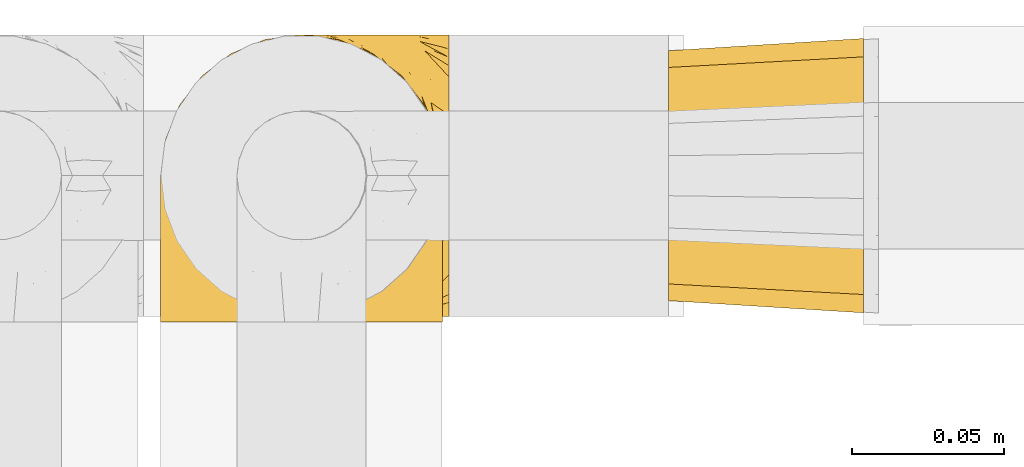
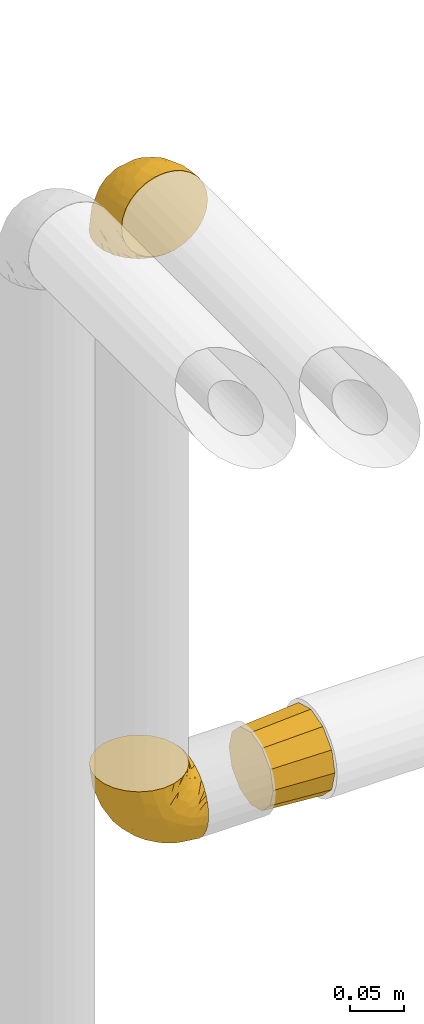
# One storey, part 307 of 827: 3 coverings.
"""IFC2X3 building model written with IfcOpenShell, lengths in millimetres."""

import ifcopenshell
import ifcopenshell.guid

model = None  # the IFC model being written
_history = None  # IfcOwnerHistory: only IFC2X3 demands one
_inside = {}  # id of a spatial element -> (the spatial element, [elements in it])
_under = {}  # id of a project, library or spatial element -> (it, [spatial elements below it])
_declared = {}  # id of a project -> (the project, [libraries it declares])
_typed = {}  # id of a type object -> (the type object, [elements of that type])
_made_of = {}  # id of a material, layer set ... -> (it, [elements and type objects made of it])


def new_model(schema):
    """Start an empty IFC model of exactly this schema.

    Asked for "IFC4X3", IfcOpenShell would pick the latest addendum, in which some entities
    have other attributes; the version numbers below select the first issue.
    IFC2X3 requires an IfcOwnerHistory on every rooted entity: one is made here for all.
    """
    global model, _history
    if schema == "IFC4X3":
        model = ifcopenshell.file(schema_version=(4, 3, 0, 0))
    else:
        model = ifcopenshell.file(schema=schema)
    _inside.clear()
    _under.clear()
    _declared.clear()
    _typed.clear()
    _made_of.clear()
    _history = None
    if model.schema == "IFC2X3":
        org = make("IfcOrganization", Name="unknown")
        user = make(
            "IfcPersonAndOrganization",
            ThePerson=make("IfcPerson", FamilyName="unknown"),
            TheOrganization=org,
        )
        app = make(
            "IfcApplication",
            ApplicationDeveloper=org,
            Version="unknown",
            ApplicationFullName="unknown",
            ApplicationIdentifier="unknown",
        )
        _history = make(
            "IfcOwnerHistory",
            OwningUser=user,
            OwningApplication=app,
            ChangeAction="ADDED",
            CreationDate=0,
        )
    return model


def make(cls, **values):
    """One entity of the class cls with the attributes given. An attribute that is None is left unset."""
    return model.create_entity(
        cls, **{name: value for name, value in values.items() if value is not None}
    )


def entity(cls, *values):
    """Any entity or typed value of the class cls, its attributes in the order of the schema. None: left unset."""
    e = model.create_entity(cls)
    for i, value in enumerate(values):
        if value is not None:
            e[i] = value
    return e


def rooted(cls, **values):
    """An entity with a GlobalId (a new one), such as an element, a storey or a relation."""
    return make(cls, GlobalId=ifcopenshell.guid.new(), OwnerHistory=_history, **values)


def si_unit(unit_type, name, prefix=None):
    """IfcSIUnit, for example si_unit("LENGTHUNIT", "METRE", prefix="MILLI")."""
    return make("IfcSIUnit", UnitType=unit_type, Prefix=prefix, Name=name)


def converted_unit(unit_type, name, factor, base, dimensions=None, offset=None):
    """IfcConversionBasedUnit, such as the inch: factor (a typed value) times the base unit."""
    return make(
        "IfcConversionBasedUnit"
        if offset is None
        else "IfcConversionBasedUnitWithOffset",
        ConversionOffset=offset,
        Dimensions=None
        if dimensions is None
        else entity("IfcDimensionalExponents", *dimensions),
        UnitType=unit_type,
        Name=name,
        ConversionFactor=make(
            "IfcMeasureWithUnit", ValueComponent=factor, UnitComponent=base
        ),
    )


def derived_unit(unit_type, elements):
    """IfcDerivedUnit: a product of units, each with its exponent."""
    return make(
        "IfcDerivedUnit",
        Elements=[
            make("IfcDerivedUnitElement", Unit=unit, Exponent=power)
            for unit, power in elements
        ],
        UnitType=unit_type,
    )


def assignment(units):
    """IfcUnitAssignment: the units of a project."""
    return None if units is None else make("IfcUnitAssignment", Units=units)


def point(xyz):
    """IfcCartesianPoint."""
    return None if xyz is None else make("IfcCartesianPoint", Coordinates=xyz)


def direction(xyz):
    """IfcDirection."""
    return None if xyz is None else make("IfcDirection", DirectionRatios=xyz)


def frame(location, z_axis=None, x_axis=None):
    """IfcAxis2Placement3D, a coordinate frame: its origin and axes. An axis left out is left unset."""
    return make(
        "IfcAxis2Placement3D",
        Location=point(location),
        Axis=direction(z_axis),
        RefDirection=direction(x_axis),
    )


def origin():
    """The frame at (0, 0, 0) with its axes left unset."""
    return frame((0.0, 0.0, 0.0))


def place(relative_to, where):
    """IfcLocalPlacement: puts the frame where relative to a parent placement (None: the world)."""
    return make(
        "IfcLocalPlacement", PlacementRelTo=relative_to, RelativePlacement=where
    )


def context(
    kind, dimensions, precision=None, world=None, true_north=None, identifier=None
):
    """IfcGeometricRepresentationContext, for example the 3D "Model" context."""
    return make(
        "IfcGeometricRepresentationContext",
        ContextIdentifier=identifier,
        ContextType=kind,
        CoordinateSpaceDimension=dimensions,
        Precision=precision,
        WorldCoordinateSystem=world,
        TrueNorth=true_north,
    )


def subcontext(parent, identifier, kind, view, scale=None):
    """IfcGeometricRepresentationSubContext, for example "Body" below "Model"."""
    return make(
        "IfcGeometricRepresentationSubContext",
        ContextIdentifier=identifier,
        ContextType=kind,
        ParentContext=parent,
        TargetScale=scale,
        TargetView=view,
    )


def project(units=None, contexts=None):
    """IfcProject with its units and contexts."""
    return rooted(
        "IfcProject",
        Name="project",
        RepresentationContexts=contexts,
        UnitsInContext=assignment(units),
    )


def spatial(cls, under=None, at=None, **own):
    """A site, building, storey or space (cls), placed at a placement, below another one or the project."""
    s = rooted(cls, ObjectPlacement=at, **own)
    if under is not None:
        _under.setdefault(under.id(), (under, []))[1].append(s)
    return s


def faces_of(points, faces, orient=None, outer=None):
    """IfcFace entities. A face is a list of loops; a loop is a list of indices into points, from 0.

    orient and outer hold one flag for each loop. By default every Orientation is true, the
    first loop of a face is its IfcFaceOuterBound and the others are IfcFaceBound.
    """
    made = []
    for i, loops in enumerate(faces):
        bounds = []
        for j, loop in enumerate(loops):
            is_outer = j == 0 if outer is None else outer[i][j]
            bounds.append(
                make(
                    "IfcFaceOuterBound" if is_outer else "IfcFaceBound",
                    Bound=make("IfcPolyLoop", Polygon=[points[k] for k in loop]),
                    Orientation=True if orient is None else orient[i][j],
                )
            )
        made.append(make("IfcFace", Bounds=bounds))
    return made


def faceted_brep(points, faces, orient=None, outer=None, voids=None):
    """IfcFacetedBrep: a solid bounded by flat faces; with voids (closed shells), ...WithVoids."""
    shared = [point(p) for p in points]
    hull = make("IfcClosedShell", CfsFaces=faces_of(shared, faces, orient, outer))
    if voids is None:
        return make("IfcFacetedBrep", Outer=hull)
    return make(
        "IfcFacetedBrepWithVoids",
        Outer=hull,
        Voids=[
            make(cls, CfsFaces=faces_of(shared, fs, o, b)) for cls, fs, o, b in voids
        ],
    )


def shape(context_of_items, identifier, shape_type, items):
    """IfcShapeRepresentation: the items that make up one representation, for example the "Body"."""
    return make(
        "IfcShapeRepresentation",
        ContextOfItems=context_of_items,
        RepresentationIdentifier=identifier,
        RepresentationType=shape_type,
        Items=items,
    )


def made_of(thing, what):
    """Note that an element or type object is made of a material, layer set ...; save() writes the relation."""
    if what is not None:
        _made_of.setdefault(what.id(), (what, []))[1].append(thing)
    return thing


def element(
    cls,
    number,
    at=None,
    inside=None,
    cuts=None,
    type_object=None,
    material=None,
    context=None,
    identifier="Body",
    shape_type=None,
    held_by="IfcProductDefinitionShape",
    body=None,
    shapes=None,
    **own,
):
    """One element of the class cls, such as IfcWall. Its Tag is "e" and its number.

    at: its placement. inside: the storey or other place that contains it. cuts: it is an
    opening in that element (IfcRelVoidsElement). A single representation is given by context,
    identifier, shape_type and body (its items); several are given by shapes. held_by: the class
    of the entity that holds the representations. save() writes the other relations.
    """
    e = rooted(cls, Tag="e%d" % number, ObjectPlacement=at, **own)
    if body is not None:
        shapes = [shape(context, identifier, shape_type, body)]
    if shapes is not None:
        e.Representation = make(held_by, Representations=shapes)
    if inside is not None:
        _inside.setdefault(inside.id(), (inside, []))[1].append(e)
    if cuts is not None:
        rooted(
            "IfcRelVoidsElement", RelatingBuildingElement=cuts, RelatedOpeningElement=e
        )
    if type_object is not None:
        _typed.setdefault(type_object.id(), (type_object, []))[1].append(e)
    return made_of(e, material)


def aggregate(whole, parts):
    """IfcRelAggregates: a whole, such as a stair, and the parts it consists of."""
    return rooted("IfcRelAggregates", RelatingObject=whole, RelatedObjects=parts)


def save(model, path):
    """Write the relations noted so far, then the file.

    IfcRelAggregates (storeys below a building ...), IfcRelContainedInSpatialStructure (elements
    in a storey), IfcRelDefinesByType, IfcRelAssociatesMaterial and IfcRelDeclares: one each for
    every whole, place, type object, material and project.
    """
    for whole, parts in _under.values():
        aggregate(whole, parts)
    for where, things in _inside.values():
        rooted(
            "IfcRelContainedInSpatialStructure",
            RelatedElements=things,
            RelatingStructure=where,
        )
    for kind, things in _typed.values():
        rooted("IfcRelDefinesByType", RelatedObjects=things, RelatingType=kind)
    for what, things in _made_of.values():
        rooted("IfcRelAssociatesMaterial", RelatedObjects=things, RelatingMaterial=what)
    for by, libraries in _declared.values():
        rooted("IfcRelDeclares", RelatingContext=by, RelatedDefinitions=libraries)
    model.write(path)


model = new_model("IFC2X3")

# Units and contexts
model_context = context("Model", 3, precision=0.01, world=origin(), true_north=direction((6.12303176911189e-17, 1.0)))
body_context = subcontext(model_context, "Body", "Model", "MODEL_VIEW")
ifc_project = project(units=[si_unit("LENGTHUNIT", "METRE", prefix="MILLI"), si_unit("AREAUNIT", "SQUARE_METRE"), si_unit("VOLUMEUNIT", "CUBIC_METRE"), converted_unit("PLANEANGLEUNIT", "DEGREE", entity("IfcRatioMeasure", 0.0174532925199433), si_unit("PLANEANGLEUNIT", "RADIAN"), dimensions=[0, 0, 0, 0, 0, 0, 0]), si_unit("MASSUNIT", "GRAM", prefix="KILO"), derived_unit("MASSDENSITYUNIT", [(si_unit("MASSUNIT", "GRAM", prefix="KILO"), 1), (si_unit("LENGTHUNIT", "METRE"), -3)]), derived_unit("MOMENTOFINERTIAUNIT", [(si_unit("LENGTHUNIT", "METRE"), 4)]), si_unit("TIMEUNIT", "SECOND"), si_unit("FREQUENCYUNIT", "HERTZ"), si_unit("THERMODYNAMICTEMPERATUREUNIT", "DEGREE_CELSIUS"), derived_unit("THERMALTRANSMITTANCEUNIT", [(si_unit("MASSUNIT", "GRAM", prefix="KILO"), 1), (si_unit("THERMODYNAMICTEMPERATUREUNIT", "KELVIN"), -1), (si_unit("TIMEUNIT", "SECOND"), -3)]), derived_unit("VOLUMETRICFLOWRATEUNIT", [(si_unit("LENGTHUNIT", "METRE"), 3), (si_unit("TIMEUNIT", "SECOND"), -1)]), derived_unit("MASSFLOWRATEUNIT", [(si_unit("MASSUNIT", "GRAM", prefix="KILO"), 1), (si_unit("TIMEUNIT", "SECOND"), -1)]), derived_unit("ROTATIONALFREQUENCYUNIT", [(si_unit("TIMEUNIT", "SECOND"), -1)]), si_unit("ELECTRICCURRENTUNIT", "AMPERE"), si_unit("ELECTRICVOLTAGEUNIT", "VOLT"), si_unit("POWERUNIT", "WATT"), si_unit("FORCEUNIT", "NEWTON", prefix="KILO"), si_unit("ILLUMINANCEUNIT", "LUX"), si_unit("LUMINOUSFLUXUNIT", "LUMEN"), si_unit("LUMINOUSINTENSITYUNIT", "CANDELA"), derived_unit("USERDEFINED", [(si_unit("MASSUNIT", "GRAM", prefix="KILO"), -1), (si_unit("LENGTHUNIT", "METRE"), -2), (si_unit("TIMEUNIT", "SECOND"), 3), (si_unit("LUMINOUSFLUXUNIT", "LUMEN"), 1)]), derived_unit("LINEARVELOCITYUNIT", [(si_unit("LENGTHUNIT", "METRE"), 1), (si_unit("TIMEUNIT", "SECOND"), -1)]), si_unit("PRESSUREUNIT", "PASCAL"), derived_unit("USERDEFINED", [(si_unit("LENGTHUNIT", "METRE"), -2), (si_unit("MASSUNIT", "GRAM", prefix="KILO"), 1), (si_unit("TIMEUNIT", "SECOND"), -2)]), derived_unit("LINEARFORCEUNIT", [(si_unit("MASSUNIT", "GRAM", prefix="KILO"), 1), (si_unit("LENGTHUNIT", "METRE"), 1), (si_unit("TIMEUNIT", "SECOND"), -2), (si_unit("LENGTHUNIT", "METRE"), -1)]), derived_unit("PLANARFORCEUNIT", [(si_unit("MASSUNIT", "GRAM", prefix="KILO"), 1), (si_unit("LENGTHUNIT", "METRE"), 1), (si_unit("TIMEUNIT", "SECOND"), -2), (si_unit("LENGTHUNIT", "METRE"), -2)])], contexts=[model_context])

# Site, building, storey
site_placement = place(None, origin())
site = spatial("IfcSite", under=ifc_project, at=site_placement, CompositionType="ELEMENT")
building_placement = place(site_placement, origin())
building = spatial("IfcBuilding", under=site, at=building_placement, CompositionType="ELEMENT")
storey_placement = place(building_placement, frame((0.0, 0.0, 28200.0)))
storey = spatial("IfcBuildingStorey", under=building, at=storey_placement, Name="08", CompositionType="ELEMENT", Elevation=28200.0)

# Coverings
covering_1_placement = place(storey_placement, frame((28292.43, 19468.41, 2252.2)))
element("IfcCovering", 1, at=covering_1_placement, inside=storey, Name=":ADSK_", ObjectType=":ADSK_", PredefinedType="INSULATION", context=body_context, shape_type="Brep", body=[
    faceted_brep([(95.8, 11.68, 18.98), (95.8, 19.0, 11.67), (95.8, 27.76, 6.17), (95.8, 37.52, 2.75), (95.8, 47.8, 1.6), (95.8, 58.08, 2.75), (95.8, 67.85, 6.17), (95.8, 76.61, 11.68), (95.8, 83.92, 19.0), (95.8, 89.42, 27.76), (95.8, 92.84, 37.52), (95.8, 94.0, 47.8), (95.8, 93.53, 51.94), (95.8, 93.18, 55.01), (95.8, 92.84, 58.08), (95.8, 91.13, 62.96), (95.8, 89.42, 67.85), (95.8, 86.66, 72.23), (95.8, 83.91, 76.61), (95.8, 80.25, 80.26), (95.8, 76.59, 83.92), (95.8, 67.83, 89.42), (95.8, 62.95, 91.13), (95.8, 58.07, 92.84), (95.8, 47.8, 94.0), (95.8, 37.51, 92.84), (95.8, 32.63, 91.13), (95.8, 27.74, 89.42), (95.8, 18.98, 83.91), (95.8, 15.33, 80.25), (95.8, 11.67, 76.59), (95.8, 8.92, 72.21), (95.8, 6.17, 67.83), (95.8, 4.46, 62.95), (95.8, 2.75, 58.07), (95.8, 2.41, 55.0), (95.8, 2.06, 51.94), (95.8, 1.6, 47.8), (95.8, 2.75, 37.51), (95.8, 6.17, 27.74), (94.0, 47.8, 95.8), (92.42, 59.75, 95.8), (87.81, 70.9, 95.8), (84.13, 75.68, 95.8), (80.46, 80.46, 95.8), (75.68, 84.13, 95.8), (70.9, 87.81, 95.8), (65.32, 90.11, 95.8), (59.75, 92.42, 95.8), (56.14, 92.9, 95.8), (54.06, 93.17, 95.8), (51.97, 93.45, 95.8), (47.8, 94.0, 95.8), (35.84, 92.42, 95.8), (24.7, 87.81, 95.8), (15.13, 80.46, 95.8), (7.78, 70.9, 95.8), (3.17, 59.75, 95.8), (1.6, 47.8, 95.8), (3.17, 35.84, 95.8), (7.78, 24.7, 95.8), (15.13, 15.13, 95.8), (24.7, 7.78, 95.8), (35.84, 3.17, 95.8), (47.8, 1.6, 95.8), (51.97, 2.14, 95.8), (56.14, 2.69, 95.8), (59.75, 3.17, 95.8), (65.32, 5.48, 95.8), (70.9, 7.78, 95.8), (75.68, 11.46, 95.8), (80.46, 15.13, 95.8), (84.13, 19.91, 95.8), (87.81, 24.7, 95.8), (92.42, 35.84, 95.8), (15.84, 23.61, 60.58), (6.99, 31.99, 74.11), (14.39, 35.87, 51.59), (6.21, 47.8, 66.69), (4.26, 40.43, 76.19), (3.39, 47.8, 84.43), (31.2, 31.83, 31.2), (26.47, 23.37, 42.88), (11.44, 21.41, 79.41), (47.66, 3.07, 60.7), (61.85, 1.6, 61.85), (59.25, 1.6, 65.75), (56.65, 1.6, 69.64), (54.05, 1.6, 73.53), (51.45, 1.6, 77.43), (19.8, 13.45, 74.59), (26.22, 15.25, 54.72), (31.58, 8.07, 64.18), (38.36, 16.0, 37.94), (51.54, 17.34, 25.89), (51.6, 10.58, 34.73), (55.97, 5.34, 42.89), (62.88, 2.39, 49.83), (41.35, 8.36, 48.58), (82.24, 10.04, 22.41), (40.88, 2.59, 78.69), (29.0, 6.28, 81.64), (74.06, 34.28, 6.22), (54.53, 38.73, 12.11), (57.98, 27.25, 14.81), (43.81, 29.88, 21.61), (38.22, 38.6, 22.41), (38.33, 23.44, 30.12), (74.76, 25.25, 10.01), (76.85, 17.23, 15.36), (84.43, 47.8, 3.39), (40.43, 47.8, 19.59), (30.01, 47.8, 30.01), (78.67, 2.53, 41.19), (92.06, 1.6, 48.54), (88.32, 1.6, 49.28), (85.6, 1.6, 49.82), (82.88, 1.6, 50.37), (80.15, 1.6, 50.91), (77.43, 1.6, 51.45), (76.36, 5.71, 31.61), (50.91, 1.6, 80.15), (50.37, 1.6, 82.88), (49.82, 1.6, 85.6), (49.28, 1.6, 88.32), (48.91, 1.6, 90.19), (48.54, 1.6, 92.06), (66.69, 47.8, 6.21), (73.53, 1.6, 54.05), (69.64, 1.6, 56.65), (65.75, 1.6, 59.25), (66.13, 11.89, 24.66), (19.59, 47.8, 40.43), (24.64, 39.69, 35.17), (53.56, 47.8, 12.9), (12.9, 47.8, 53.56), (82.81, 13.84, 85.34), (81.22, 9.16, 78.44), (86.57, 15.79, 84.37), (92.75, 25.75, 89.05), (89.68, 16.09, 82.76), (72.26, 7.51, 86.31), (64.73, 3.99, 83.73), (62.45, 2.66, 77.31), (60.63, 3.16, 87.78), (56.91, 2.35, 87.91), (58.14, 2.23, 81.29), (93.7, 38.35, 93.97), (83.4, 6.18, 70.76), (75.54, 2.7, 63.67), (79.46, 2.93, 62.62), (82.28, 16.01, 90.64), (76.25, 9.08, 84.08), (90.18, 11.68, 77.45), (87.92, 6.83, 70.34), (65.12, 4.65, 88.72), (71.71, 3.65, 71.28), (75.21, 3.61, 68.09), (78.6, 12.8, 91.07), (87.27, 2.43, 57.47), (86.94, 21.65, 91.35), (86.1, 3.7, 62.99), (94.52, 47.8, 94.52), (66.23, 3.37, 76.47), (84.69, 9.3, 76.28), (91.08, 7.03, 69.96), (71.77, 7.87, 89.86), (76.21, 7.26, 78.94), (68.59, 3.41, 73.51), (89.94, 23.81, 89.62), (76.25, 86.5, 84.09), (72.26, 88.08, 86.3), (78.6, 82.79, 91.06), (49.28, 94.0, 88.32), (48.54, 94.0, 92.06), (50.37, 94.0, 82.88), (49.82, 94.0, 85.6), (93.7, 57.24, 93.97), (89.95, 71.76, 89.63), (82.88, 94.0, 50.37), (85.6, 94.0, 49.82), (92.06, 94.0, 48.54), (88.32, 94.0, 49.28), (89.68, 79.49, 82.77), (87.92, 88.75, 70.36), (62.45, 92.93, 77.31), (66.24, 92.22, 76.47), (56.65, 94.0, 69.64), (59.25, 94.0, 65.75), (60.63, 92.43, 87.78), (56.91, 93.24, 87.91), (92.76, 69.82, 89.06), (82.28, 79.57, 90.65), (82.81, 81.74, 85.35), (54.05, 94.0, 73.53), (51.45, 94.0, 77.43), (58.14, 93.36, 81.29), (90.18, 83.9, 77.46), (84.7, 86.28, 76.29), (87.25, 93.16, 57.47), (75.58, 92.88, 63.71), (75.2, 91.98, 68.11), (83.39, 89.41, 70.77), (71.7, 91.93, 71.31), (81.22, 86.42, 78.46), (90.73, 88.82, 69.52), (79.47, 92.66, 62.64), (86.94, 73.93, 91.35), (65.75, 94.0, 59.25), (86.75, 79.5, 84.6), (86.08, 91.89, 62.98), (77.43, 94.0, 51.45), (73.53, 94.0, 54.05), (69.64, 94.0, 56.65), (64.73, 91.6, 83.73), (50.91, 94.0, 80.15), (65.12, 90.94, 88.72), (61.85, 94.0, 61.85), (68.62, 92.16, 73.56), (76.22, 88.32, 78.96), (74.03, 86.13, 91.36), (80.15, 94.0, 50.91), (49.81, 93.2, 62.87), (4.26, 55.16, 76.19), (19.95, 82.02, 73.57), (30.61, 84.29, 56.07), (25.71, 76.94, 49.77), (22.43, 68.33, 44.73), (15.85, 71.98, 60.58), (60.69, 92.52, 47.64), (40.49, 92.9, 78.32), (14.39, 59.72, 51.59), (6.99, 63.6, 74.11), (29.56, 88.89, 76.04), (11.45, 74.18, 79.41), (57.98, 68.35, 14.82), (74.06, 61.33, 6.22), (54.52, 56.86, 12.12), (43.47, 68.62, 23.51), (31.2, 63.76, 31.2), (33.27, 72.19, 34.96), (64.26, 88.69, 33.86), (74.29, 92.19, 38.94), (80.41, 89.75, 30.23), (41.67, 59.86, 20.67), (24.64, 55.9, 35.17), (73.62, 77.99, 15.85), (78.98, 85.21, 22.59), (53.69, 74.99, 21.56), (42.86, 90.23, 55.94), (79.66, 70.75, 9.19), (58.41, 81.72, 25.79), (47.11, 86.53, 41.16), (38.37, 79.6, 37.95)], [[[0, 1, 2, 3, 4, 5, 6, 7, 8, 9, 10, 11, 12, 13, 14, 15, 16, 17, 18, 19, 20, 21, 22, 23, 24, 25, 26, 27, 28, 29, 30, 31, 32, 33, 34, 35, 36, 37, 38, 39]], [[40, 41, 42, 43, 44, 45, 46, 47, 48, 49, 50, 51, 52, 53, 54, 55, 56, 57, 58, 59, 60, 61, 62, 63, 64, 65, 66, 67, 68, 69, 70, 71, 72, 73, 74]], [[75, 76, 77]], [[78, 79, 80]], [[77, 81, 82]], [[76, 75, 83]], [[84, 85, 86, 87, 88, 89]], [[90, 91, 92]], [[76, 60, 59]], [[93, 94, 95]], [[90, 62, 61]], [[83, 61, 60]], [[96, 97, 84]], [[98, 93, 95]], [[0, 39, 99]], [[100, 84, 89]], [[62, 101, 63]], [[2, 102, 3]], [[92, 84, 100]], [[103, 102, 104]], [[103, 105, 106]], [[93, 107, 94]], [[1, 108, 2]], [[92, 101, 90]], [[108, 1, 109]], [[102, 110, 3]], [[93, 82, 107]], [[102, 108, 104]], [[111, 106, 112]], [[109, 0, 99]], [[113, 37, 114, 115, 116, 117, 118, 119]], [[120, 38, 113]], [[100, 89, 121, 122, 123, 124, 125, 126, 64]], [[127, 102, 103]], [[97, 119, 128, 129, 130, 85]], [[99, 120, 131]], [[132, 133, 77]], [[59, 80, 79]], [[1, 0, 109]], [[98, 84, 92]], [[94, 109, 131]], [[120, 39, 38]], [[93, 91, 82]], [[104, 94, 105]], [[97, 113, 119]], [[95, 120, 96]], [[83, 90, 61]], [[91, 93, 98]], [[64, 63, 100]], [[100, 63, 101]], [[77, 76, 79]], [[133, 106, 81]], [[84, 97, 85]], [[113, 96, 120]], [[113, 97, 96]], [[37, 113, 38]], [[110, 102, 127]], [[110, 4, 3]], [[103, 111, 134, 127]], [[90, 75, 91]], [[82, 81, 107]], [[91, 75, 82]], [[77, 82, 75]], [[76, 83, 60]], [[90, 83, 75]], [[105, 107, 81]], [[94, 131, 95]], [[105, 94, 107]], [[109, 94, 104]], [[120, 95, 131]], [[98, 95, 96]], [[84, 98, 96]], [[98, 92, 91]], [[106, 105, 81]], [[103, 104, 105]], [[112, 106, 133]], [[103, 106, 111]], [[112, 133, 132]], [[81, 77, 133]], [[77, 78, 135, 132]], [[120, 99, 39]], [[109, 99, 131]], [[59, 58, 80]], [[59, 79, 76]], [[90, 101, 62]], [[100, 101, 92]], [[2, 108, 102]], [[109, 104, 108]], [[78, 77, 79]], [[136, 137, 138]], [[27, 139, 140]], [[141, 142, 143]], [[144, 145, 121]], [[146, 89, 88]], [[147, 139, 25]], [[148, 149, 150]], [[136, 151, 152]], [[147, 40, 74]], [[24, 147, 25]], [[153, 148, 154]], [[33, 116, 34]], [[73, 72, 151]], [[114, 37, 36, 35, 34, 116, 115]], [[146, 155, 144]], [[156, 85, 130]], [[157, 149, 148]], [[151, 158, 152]], [[117, 33, 159]], [[29, 153, 154]], [[160, 74, 73]], [[161, 128, 119]], [[66, 65, 64, 126, 125, 124, 123, 122, 67]], [[162, 147, 24]], [[27, 140, 28]], [[149, 129, 150]], [[139, 27, 26, 25]], [[68, 144, 69]], [[129, 128, 150]], [[163, 87, 86]], [[130, 129, 149]], [[122, 145, 67]], [[153, 164, 148]], [[161, 119, 159]], [[165, 30, 154]], [[150, 154, 148]], [[128, 161, 150]], [[30, 165, 31]], [[145, 144, 68]], [[89, 146, 144]], [[87, 163, 143]], [[166, 155, 142]], [[88, 87, 143]], [[161, 154, 150]], [[154, 30, 29]], [[29, 28, 153]], [[28, 140, 153]], [[164, 153, 140]], [[140, 137, 164]], [[157, 148, 164]], [[156, 130, 157]], [[164, 137, 157]], [[157, 137, 156]], [[167, 137, 136]], [[168, 85, 156]], [[152, 168, 167]], [[167, 168, 156]], [[163, 152, 141]], [[71, 158, 72]], [[152, 167, 136]], [[88, 142, 146]], [[144, 155, 69]], [[146, 142, 155]], [[70, 166, 71]], [[142, 141, 166]], [[70, 69, 155]], [[141, 158, 71]], [[160, 73, 151]], [[138, 137, 140]], [[160, 136, 169]], [[136, 160, 151]], [[74, 160, 169]], [[152, 158, 141]], [[151, 72, 158]], [[168, 152, 163]], [[137, 167, 156]], [[163, 86, 168]], [[85, 168, 86]], [[116, 33, 117]], [[130, 149, 157]], [[67, 145, 68]], [[121, 89, 144]], [[145, 122, 121]], [[40, 147, 162]], [[169, 147, 74]], [[159, 33, 32]], [[161, 159, 32]], [[159, 119, 118, 117]], [[139, 147, 169]], [[139, 169, 138]], [[161, 32, 31]], [[141, 143, 163]], [[88, 143, 142]], [[71, 166, 141]], [[155, 166, 70]], [[139, 138, 140]], [[169, 136, 138]], [[154, 161, 165]], [[161, 31, 165]], [[170, 171, 172]], [[173, 174, 52, 51, 50, 49, 48, 175, 176]], [[177, 178, 41]], [[179, 15, 180]], [[12, 11, 181, 182, 180, 14, 13]], [[183, 21, 20]], [[19, 18, 184]], [[185, 186, 187]], [[186, 188, 187]], [[43, 172, 44]], [[189, 190, 47]], [[23, 22, 21, 191]], [[170, 192, 193]], [[40, 162, 177]], [[194, 195, 196]], [[24, 23, 177]], [[197, 198, 183]], [[199, 15, 179]], [[178, 177, 191]], [[47, 46, 189]], [[200, 201, 202]], [[201, 203, 204]], [[205, 206, 184]], [[207, 41, 178]], [[16, 15, 199]], [[14, 180, 15]], [[202, 201, 198]], [[208, 201, 200]], [[162, 24, 177]], [[48, 47, 190]], [[196, 195, 189]], [[197, 184, 202]], [[204, 193, 209]], [[210, 211, 212]], [[206, 212, 213]], [[205, 17, 210]], [[184, 206, 202]], [[210, 212, 206]], [[185, 194, 214]], [[189, 215, 190]], [[216, 45, 214]], [[186, 171, 170]], [[189, 216, 196]], [[197, 20, 19]], [[194, 185, 187]], [[197, 183, 20]], [[184, 197, 19]], [[197, 202, 198]], [[206, 200, 202]], [[204, 183, 198]], [[201, 208, 203]], [[203, 208, 217]], [[204, 198, 201]], [[217, 188, 218]], [[193, 219, 170]], [[171, 186, 185]], [[170, 218, 186]], [[170, 219, 218]], [[42, 207, 192]], [[171, 220, 172]], [[216, 189, 46]], [[214, 194, 196]], [[44, 220, 45]], [[214, 196, 216]], [[216, 46, 45]], [[214, 45, 220]], [[192, 43, 42]], [[204, 203, 219]], [[207, 193, 192]], [[209, 193, 178]], [[41, 207, 42]], [[193, 207, 178]], [[43, 192, 172]], [[170, 172, 192]], [[204, 219, 193]], [[219, 203, 218]], [[217, 218, 203]], [[188, 186, 218]], [[206, 213, 200]], [[208, 200, 213]], [[199, 210, 16]], [[215, 189, 195]], [[215, 175, 190]], [[175, 48, 190]], [[199, 179, 221, 211]], [[210, 199, 211]], [[23, 191, 177]], [[40, 177, 41]], [[191, 183, 209]], [[21, 183, 191]], [[205, 18, 17]], [[17, 16, 210]], [[171, 185, 214]], [[172, 220, 44]], [[214, 220, 171]], [[191, 209, 178]], [[204, 209, 183]], [[206, 205, 210]], [[18, 205, 184]], [[222, 195, 194, 187, 188, 217]], [[57, 223, 80]], [[224, 225, 226]], [[226, 227, 228]], [[229, 217, 208, 213, 212, 211]], [[230, 52, 174, 173, 176, 175, 215, 195]], [[231, 232, 228]], [[231, 78, 223]], [[223, 57, 232]], [[224, 233, 225]], [[233, 54, 53]], [[234, 232, 56]], [[56, 55, 234]], [[234, 224, 228]], [[235, 236, 237]], [[224, 55, 54]], [[238, 239, 240]], [[52, 230, 53]], [[241, 242, 243]], [[239, 244, 245]], [[11, 10, 242]], [[236, 6, 5]], [[7, 246, 8]], [[8, 247, 9]], [[238, 248, 235]], [[222, 229, 249]], [[242, 211, 221, 179, 180, 182, 181, 11]], [[233, 53, 230]], [[111, 112, 244]], [[250, 6, 236]], [[247, 251, 241]], [[6, 250, 7]], [[127, 236, 110]], [[249, 229, 252]], [[247, 8, 246]], [[235, 246, 250]], [[236, 5, 110]], [[235, 244, 238]], [[237, 236, 127]], [[243, 9, 247]], [[252, 229, 241]], [[56, 232, 57]], [[222, 230, 195]], [[225, 249, 252]], [[249, 233, 230]], [[54, 233, 224]], [[231, 228, 227]], [[245, 132, 231]], [[249, 225, 233]], [[226, 225, 253]], [[235, 250, 236]], [[246, 7, 250]], [[251, 247, 246]], [[243, 247, 241]], [[248, 246, 235]], [[252, 251, 253]], [[229, 222, 217]], [[230, 222, 249]], [[5, 4, 110]], [[237, 127, 134, 111]], [[238, 244, 239]], [[224, 234, 55]], [[232, 234, 228]], [[242, 241, 229]], [[10, 9, 243]], [[211, 242, 229]], [[10, 243, 242]], [[80, 223, 78]], [[80, 58, 57]], [[231, 223, 232]], [[227, 240, 239]], [[224, 226, 228]], [[240, 226, 253]], [[227, 239, 245]], [[226, 240, 227]], [[251, 248, 253]], [[240, 253, 248]], [[244, 235, 237]], [[237, 111, 244]], [[132, 245, 112]], [[112, 245, 244]], [[135, 78, 231, 132]], [[227, 245, 231]], [[248, 238, 240]], [[246, 248, 251]], [[251, 252, 241]], [[225, 252, 253]]]),
])
covering_2_placement = place(storey_placement, frame((28292.09, 19466.61, 2950.29)))
element("IfcCovering", 2, at=covering_2_placement, inside=storey, Name=":ADSK_", ObjectType=":ADSK_", PredefinedType="INSULATION", context=body_context, shape_type="Brep", body=[
    faceted_brep([(92.83, 1.6, 59.93), (89.41, 1.6, 69.69), (83.9, 1.6, 78.45), (76.57, 1.6, 85.76), (67.81, 1.6, 91.26), (58.05, 1.6, 94.67), (47.77, 1.6, 95.82), (37.49, 1.6, 94.65), (27.72, 1.6, 91.23), (18.96, 1.6, 85.72), (11.65, 1.6, 78.4), (6.16, 1.6, 69.64), (2.75, 1.6, 59.87), (1.6, 1.6, 49.6), (2.06, 1.6, 45.45), (2.41, 1.6, 42.38), (2.76, 1.6, 39.31), (4.47, 1.6, 34.43), (6.18, 1.6, 29.54), (8.94, 1.6, 25.17), (11.7, 1.6, 20.79), (15.36, 1.6, 17.13), (19.02, 1.6, 13.48), (27.78, 1.6, 7.98), (32.66, 1.6, 6.28), (37.54, 1.6, 4.57), (47.82, 1.6, 3.42), (58.1, 1.6, 4.58), (62.99, 1.6, 6.3), (67.87, 1.6, 8.01), (76.63, 1.6, 13.52), (80.28, 1.6, 17.18), (83.94, 1.6, 20.84), (86.69, 1.6, 25.22), (89.43, 1.6, 29.6), (91.14, 1.6, 34.49), (92.84, 1.6, 39.37), (93.19, 1.6, 42.43), (93.53, 1.6, 45.5), (94.0, 1.6, 49.64), (47.82, 3.4, 1.62), (35.86, 4.97, 1.61), (24.72, 9.58, 1.61), (19.94, 13.26, 1.6), (15.15, 16.93, 1.6), (11.48, 21.71, 1.6), (7.81, 26.5, 1.6), (5.5, 32.07, 1.6), (3.19, 37.64, 1.6), (2.72, 41.25, 1.6), (2.44, 43.34, 1.6), (2.17, 45.42, 1.6), (1.62, 49.6, 1.6), (3.19, 61.55, 1.6), (7.81, 72.7, 1.6), (15.15, 82.26, 1.6), (24.72, 89.61, 1.61), (35.86, 94.22, 1.61), (47.82, 95.8, 1.62), (59.78, 94.22, 1.63), (70.92, 89.61, 1.63), (80.49, 82.26, 1.64), (87.83, 72.7, 1.64), (92.45, 61.55, 1.64), (94.02, 49.6, 1.64), (93.47, 45.42, 1.64), (92.92, 41.25, 1.64), (92.45, 37.64, 1.64), (90.14, 32.07, 1.64), (87.83, 26.5, 1.64), (84.16, 21.71, 1.64), (80.49, 16.93, 1.64), (75.7, 13.26, 1.63), (70.92, 9.58, 1.63), (59.78, 4.97, 1.63), (71.99, 81.55, 36.84), (63.62, 90.4, 23.31), (59.72, 83.0, 45.83), (47.81, 91.18, 30.73), (55.18, 93.13, 21.23), (47.81, 94.0, 12.98), (63.75, 66.19, 66.23), (72.22, 70.92, 54.55), (74.19, 85.95, 18.01), (92.53, 49.74, 36.74), (94.0, 35.54, 35.59), (94.0, 38.14, 31.69), (94.01, 40.74, 27.8), (94.01, 43.34, 23.91), (94.01, 45.94, 20.01), (82.16, 77.59, 22.84), (80.34, 71.17, 42.72), (87.53, 65.81, 33.26), (79.58, 59.03, 59.49), (78.24, 45.85, 71.54), (85.0, 45.79, 62.7), (90.25, 41.42, 54.55), (93.2, 34.51, 47.61), (87.23, 56.04, 48.86), (85.54, 15.15, 75.03), (93.02, 56.51, 18.75), (89.33, 68.39, 15.79), (61.29, 23.33, 91.2), (56.84, 42.86, 85.31), (68.32, 39.42, 82.61), (65.7, 53.58, 75.81), (56.98, 59.17, 75.01), (72.14, 59.06, 67.3), (70.32, 22.63, 87.41), (78.35, 20.55, 82.08), (47.77, 12.96, 94.02), (47.78, 56.96, 77.83), (47.79, 67.38, 67.41), (93.06, 18.72, 56.25), (94.0, 5.33, 48.9), (94.0, 9.07, 48.16), (94.0, 11.79, 47.62), (94.0, 14.51, 47.07), (94.0, 17.24, 46.53), (94.0, 19.96, 45.99), (89.87, 21.03, 65.83), (94.01, 46.48, 17.29), (94.01, 47.03, 14.56), (94.02, 47.57, 11.84), (94.02, 48.11, 9.11), (94.02, 48.48, 7.25), (94.02, 48.85, 5.38), (47.77, 30.7, 91.21), (94.0, 23.86, 43.39), (94.0, 27.75, 40.79), (94.0, 31.64, 38.19), (83.69, 31.26, 72.77), (47.79, 77.8, 56.99), (55.9, 72.75, 62.25), (47.78, 43.83, 84.52), (47.8, 84.49, 43.86), (81.77, 14.58, 12.09), (86.44, 16.17, 18.99), (79.82, 10.82, 13.06), (69.86, 4.64, 8.38), (79.52, 7.71, 14.67), (88.1, 25.13, 11.13), (91.62, 32.66, 13.71), (92.94, 34.94, 20.13), (92.45, 36.76, 9.66), (93.26, 40.48, 9.53), (93.37, 39.25, 16.15), (57.27, 3.69, 3.45), (89.42, 13.99, 26.67), (92.9, 21.85, 33.77), (92.67, 17.93, 34.81), (79.6, 15.11, 6.79), (86.53, 21.14, 13.36), (83.93, 7.21, 19.99), (88.78, 9.47, 27.1), (90.96, 32.27, 8.71), (91.95, 25.68, 26.15), (91.99, 22.18, 29.35), (82.81, 18.79, 6.37), (93.17, 10.12, 39.97), (73.96, 10.45, 6.08), (91.9, 11.29, 34.45), (47.82, 2.87, 2.89), (92.24, 31.16, 20.97), (86.3, 12.7, 21.16), (88.57, 6.31, 27.47), (87.74, 25.62, 7.58), (88.35, 21.18, 18.5), (92.19, 28.81, 23.92), (71.8, 7.45, 7.81), (7.28, 21.17, 18.44), (9.19, 16.17, 18.94), (3.67, 25.69, 26.08), (1.62, 48.11, 9.07), (1.62, 48.85, 5.33), (1.61, 47.03, 14.51), (1.62, 47.57, 11.79), (38.37, 3.69, 3.44), (23.86, 7.44, 7.77), (1.6, 14.51, 47.03), (1.6, 11.79, 47.57), (1.6, 5.33, 48.85), (1.6, 9.07, 48.11), (16.12, 7.71, 14.63), (6.85, 9.47, 27.03), (2.68, 34.94, 20.08), (3.39, 31.16, 20.92), (1.61, 40.74, 27.75), (1.6, 38.14, 31.64), (12.83, 18.79, 6.33), (3.19, 36.76, 9.61), (2.37, 40.48, 9.48), (25.79, 4.63, 8.34), (9.11, 21.14, 13.3), (16.04, 15.11, 6.75), (13.87, 14.58, 12.05), (1.61, 43.34, 23.86), (1.61, 45.94, 19.96), (2.25, 39.25, 16.1), (11.7, 7.21, 19.94), (9.32, 12.69, 21.1), (2.43, 10.14, 39.92), (2.72, 21.81, 33.68), (3.62, 22.19, 29.28), (6.2, 14.0, 26.62), (6.78, 6.66, 27.88), (2.94, 17.92, 34.75), (21.68, 10.45, 6.05), (1.6, 31.64, 38.14), (16.11, 10.64, 12.8), (3.7, 11.31, 34.41), (1.6, 19.96, 45.94), (1.6, 23.86, 43.34), (1.6, 27.75, 40.74), (4.01, 32.66, 13.66), (1.61, 46.48, 17.24), (4.67, 32.27, 8.67), (7.53, 25.13, 11.09), (1.6, 35.54, 35.54), (3.44, 28.77, 23.83), (9.49, 23.36, 6.03), (1.6, 17.24, 46.48), (2.4, 47.58, 34.53), (40.44, 93.13, 21.22), (13.58, 77.44, 23.82), (11.31, 66.78, 41.32), (18.65, 71.68, 47.63), (27.26, 74.96, 52.67), (23.62, 81.55, 36.83), (3.07, 36.7, 49.75), (2.71, 56.9, 19.07), (35.87, 83.0, 45.82), (32.0, 90.4, 23.3), (6.72, 67.83, 21.36), (21.43, 85.95, 17.99), (27.22, 39.41, 82.59), (34.24, 23.33, 91.19), (38.71, 42.87, 85.29), (26.96, 53.92, 73.9), (31.82, 66.19, 66.21), (23.4, 64.12, 62.44), (6.9, 33.13, 63.54), (3.4, 23.1, 58.45), (5.83, 16.98, 67.16), (35.71, 55.72, 76.74), (39.68, 72.75, 62.24), (17.58, 23.77, 81.55), (10.37, 18.41, 74.8), (20.58, 43.7, 75.84), (5.36, 54.53, 41.45), (24.82, 17.73, 88.21), (13.86, 38.98, 71.61), (9.06, 50.28, 56.24), (15.99, 59.02, 59.45)], [[[0, 1, 2, 3, 4, 5, 6, 7, 8, 9, 10, 11, 12, 13, 14, 15, 16, 17, 18, 19, 20, 21, 22, 23, 24, 25, 26, 27, 28, 29, 30, 31, 32, 33, 34, 35, 36, 37, 38, 39]], [[40, 41, 42, 43, 44, 45, 46, 47, 48, 49, 50, 51, 52, 53, 54, 55, 56, 57, 58, 59, 60, 61, 62, 63, 64, 65, 66, 67, 68, 69, 70, 71, 72, 73, 74]], [[75, 76, 77]], [[78, 79, 80]], [[77, 81, 82]], [[76, 75, 83]], [[84, 85, 86, 87, 88, 89]], [[90, 91, 92]], [[76, 60, 59]], [[93, 94, 95]], [[90, 62, 61]], [[83, 61, 60]], [[96, 97, 84]], [[98, 93, 95]], [[2, 1, 99]], [[100, 84, 89]], [[62, 101, 63]], [[4, 102, 5]], [[92, 84, 100]], [[103, 102, 104]], [[103, 105, 106]], [[93, 107, 94]], [[3, 108, 4]], [[92, 101, 90]], [[108, 3, 109]], [[102, 110, 5]], [[93, 82, 107]], [[102, 108, 104]], [[111, 106, 112]], [[109, 2, 99]], [[113, 39, 114, 115, 116, 117, 118, 119]], [[120, 0, 113]], [[100, 89, 121, 122, 123, 124, 125, 126, 64]], [[127, 102, 103]], [[97, 119, 128, 129, 130, 85]], [[99, 120, 131]], [[132, 133, 77]], [[59, 80, 79]], [[3, 2, 109]], [[98, 84, 92]], [[94, 109, 131]], [[120, 1, 0]], [[93, 91, 82]], [[104, 94, 105]], [[97, 113, 119]], [[95, 120, 96]], [[83, 90, 61]], [[91, 93, 98]], [[64, 63, 100]], [[100, 63, 101]], [[77, 76, 79]], [[133, 106, 81]], [[84, 97, 85]], [[113, 96, 120]], [[113, 97, 96]], [[39, 113, 0]], [[110, 102, 127]], [[110, 6, 5]], [[103, 111, 134, 127]], [[90, 75, 91]], [[82, 81, 107]], [[91, 75, 82]], [[77, 82, 75]], [[76, 83, 60]], [[90, 83, 75]], [[105, 107, 81]], [[94, 131, 95]], [[105, 94, 107]], [[109, 94, 104]], [[120, 95, 131]], [[98, 95, 96]], [[84, 98, 96]], [[98, 92, 91]], [[106, 105, 81]], [[103, 104, 105]], [[112, 106, 133]], [[103, 106, 111]], [[112, 133, 132]], [[81, 77, 133]], [[77, 78, 135, 132]], [[120, 99, 1]], [[109, 99, 131]], [[59, 58, 80]], [[59, 79, 76]], [[90, 101, 62]], [[100, 101, 92]], [[4, 108, 102]], [[109, 104, 108]], [[78, 77, 79]], [[136, 137, 138]], [[29, 139, 140]], [[141, 142, 143]], [[144, 145, 121]], [[146, 89, 88]], [[147, 139, 27]], [[148, 149, 150]], [[136, 151, 152]], [[147, 40, 74]], [[26, 147, 27]], [[153, 148, 154]], [[35, 116, 36]], [[73, 72, 151]], [[114, 39, 38, 37, 36, 116, 115]], [[146, 155, 144]], [[156, 85, 130]], [[157, 149, 148]], [[151, 158, 152]], [[117, 35, 159]], [[31, 153, 154]], [[160, 74, 73]], [[161, 128, 119]], [[66, 65, 64, 126, 125, 124, 123, 122, 67]], [[162, 147, 26]], [[29, 140, 30]], [[149, 129, 150]], [[139, 29, 28, 27]], [[68, 144, 69]], [[129, 128, 150]], [[163, 87, 86]], [[130, 129, 149]], [[122, 145, 67]], [[153, 164, 148]], [[161, 119, 159]], [[165, 32, 154]], [[150, 154, 148]], [[128, 161, 150]], [[32, 165, 33]], [[145, 144, 68]], [[89, 146, 144]], [[87, 163, 143]], [[166, 155, 142]], [[88, 87, 143]], [[161, 154, 150]], [[154, 32, 31]], [[31, 30, 153]], [[30, 140, 153]], [[164, 153, 140]], [[140, 137, 164]], [[157, 148, 164]], [[156, 130, 157]], [[164, 137, 157]], [[157, 137, 156]], [[167, 137, 136]], [[168, 85, 156]], [[152, 168, 167]], [[167, 168, 156]], [[163, 152, 141]], [[71, 158, 72]], [[152, 167, 136]], [[88, 142, 146]], [[144, 155, 69]], [[146, 142, 155]], [[70, 166, 71]], [[142, 141, 166]], [[70, 69, 155]], [[141, 158, 71]], [[160, 73, 151]], [[138, 137, 140]], [[160, 136, 169]], [[136, 160, 151]], [[74, 160, 169]], [[152, 158, 141]], [[151, 72, 158]], [[168, 152, 163]], [[137, 167, 156]], [[163, 86, 168]], [[85, 168, 86]], [[116, 35, 117]], [[130, 149, 157]], [[67, 145, 68]], [[121, 89, 144]], [[145, 122, 121]], [[40, 147, 162]], [[169, 147, 74]], [[159, 35, 34]], [[161, 159, 34]], [[159, 119, 118, 117]], [[139, 147, 169]], [[139, 169, 138]], [[161, 34, 33]], [[141, 143, 163]], [[88, 143, 142]], [[71, 166, 141]], [[155, 166, 70]], [[139, 138, 140]], [[169, 136, 138]], [[154, 161, 165]], [[161, 33, 165]], [[170, 171, 172]], [[173, 174, 52, 51, 50, 49, 48, 175, 176]], [[177, 178, 41]], [[179, 17, 180]], [[14, 13, 181, 182, 180, 16, 15]], [[183, 23, 22]], [[21, 20, 184]], [[185, 186, 187]], [[186, 188, 187]], [[43, 189, 44]], [[190, 191, 47]], [[25, 24, 23, 192]], [[193, 194, 195]], [[40, 162, 177]], [[196, 197, 198]], [[26, 25, 177]], [[199, 200, 183]], [[201, 17, 179]], [[47, 46, 190]], [[202, 203, 204]], [[203, 172, 171]], [[205, 206, 184]], [[207, 41, 178]], [[18, 17, 201]], [[16, 180, 17]], [[204, 203, 200]], [[208, 203, 202]], [[162, 26, 177]], [[48, 47, 191]], [[198, 197, 190]], [[199, 184, 204]], [[171, 195, 209]], [[210, 211, 212]], [[206, 212, 213]], [[205, 19, 210]], [[184, 206, 204]], [[210, 212, 206]], [[185, 196, 214]], [[190, 215, 191]], [[216, 45, 214]], [[186, 217, 193]], [[190, 216, 198]], [[199, 22, 21]], [[196, 185, 187]], [[199, 183, 22]], [[184, 199, 21]], [[199, 204, 200]], [[206, 202, 204]], [[171, 183, 200]], [[203, 208, 172]], [[172, 208, 218]], [[171, 200, 203]], [[218, 188, 219]], [[195, 170, 193]], [[217, 186, 185]], [[193, 219, 186]], [[193, 170, 219]], [[207, 194, 42]], [[217, 220, 189]], [[216, 190, 46]], [[214, 196, 198]], [[44, 220, 45]], [[214, 198, 216]], [[216, 46, 45]], [[214, 45, 220]], [[42, 194, 43]], [[189, 193, 217]], [[207, 195, 194]], [[209, 195, 178]], [[41, 207, 42]], [[195, 207, 178]], [[43, 194, 189]], [[193, 189, 194]], [[171, 170, 195]], [[170, 172, 219]], [[218, 219, 172]], [[188, 186, 219]], [[206, 213, 202]], [[208, 202, 213]], [[201, 210, 18]], [[215, 190, 197]], [[215, 175, 191]], [[175, 48, 191]], [[201, 179, 221, 211]], [[210, 201, 211]], [[25, 192, 177]], [[40, 177, 41]], [[178, 177, 192]], [[23, 183, 192]], [[209, 192, 183]], [[205, 20, 19]], [[19, 18, 210]], [[217, 185, 214]], [[189, 220, 44]], [[214, 220, 217]], [[192, 209, 178]], [[171, 209, 183]], [[206, 205, 210]], [[20, 205, 184]], [[222, 197, 196, 187, 188, 218]], [[57, 223, 80]], [[224, 225, 226]], [[226, 227, 228]], [[229, 218, 208, 213, 212, 211]], [[230, 52, 174, 173, 176, 175, 215, 197]], [[231, 232, 228]], [[231, 78, 223]], [[223, 57, 232]], [[224, 233, 225]], [[233, 54, 53]], [[234, 232, 56]], [[56, 55, 234]], [[234, 224, 228]], [[235, 236, 237]], [[224, 55, 54]], [[238, 239, 240]], [[52, 230, 53]], [[241, 242, 243]], [[239, 244, 245]], [[13, 12, 242]], [[236, 8, 7]], [[9, 246, 10]], [[10, 247, 11]], [[238, 248, 235]], [[222, 229, 249]], [[242, 211, 221, 179, 180, 182, 181, 13]], [[233, 53, 230]], [[111, 112, 244]], [[250, 8, 236]], [[247, 251, 241]], [[8, 250, 9]], [[127, 236, 110]], [[249, 229, 252]], [[247, 10, 246]], [[235, 246, 250]], [[236, 7, 110]], [[235, 244, 238]], [[237, 236, 127]], [[243, 11, 247]], [[252, 229, 241]], [[56, 232, 57]], [[222, 230, 197]], [[225, 249, 252]], [[249, 233, 230]], [[54, 233, 224]], [[231, 228, 227]], [[245, 132, 231]], [[249, 225, 233]], [[226, 225, 253]], [[235, 250, 236]], [[246, 9, 250]], [[251, 247, 246]], [[243, 247, 241]], [[248, 246, 235]], [[252, 251, 253]], [[229, 222, 218]], [[230, 222, 249]], [[7, 6, 110]], [[237, 127, 134, 111]], [[238, 244, 239]], [[224, 234, 55]], [[232, 234, 228]], [[242, 241, 229]], [[12, 11, 243]], [[211, 242, 229]], [[12, 243, 242]], [[80, 223, 78]], [[80, 58, 57]], [[231, 223, 232]], [[227, 240, 239]], [[224, 226, 228]], [[240, 226, 253]], [[227, 239, 245]], [[226, 240, 227]], [[251, 248, 253]], [[240, 253, 248]], [[244, 235, 237]], [[237, 111, 244]], [[132, 245, 112]], [[112, 245, 244]], [[135, 78, 231, 132]], [[227, 245, 231]], [[248, 238, 240]], [[246, 248, 251]], [[251, 252, 241]], [[225, 252, 253]]]),
])
covering_3_placement = place(storey_placement, frame((28460.22, 19469.61, 2253.4)))
element("IfcCovering", 3, at=covering_3_placement, inside=storey, Name=":ADSK_", ObjectType=":ADSK_", PredefinedType="INSULATION", context=body_context, shape_type="Brep", body=[
    faceted_brep([(0.0, 87.6, 46.6), (0.0, 84.85, 36.35), (0.0, 82.1, 26.1), (0.0, 74.6, 18.59), (0.0, 67.1, 11.09), (0.0, 56.85, 8.34), (0.0, 46.6, 5.6), (0.0, 36.35, 8.34), (0.0, 26.1, 11.09), (0.0, 18.59, 18.59), (0.0, 11.09, 26.1), (0.0, 8.34, 36.35), (0.0, 5.6, 46.6), (0.0, 8.34, 56.85), (0.0, 11.09, 67.1), (0.0, 18.59, 74.6), (0.0, 26.1, 82.1), (0.0, 36.35, 84.85), (0.0, 46.6, 87.6), (0.0, 56.85, 84.85), (0.0, 67.1, 82.1), (0.0, 74.6, 74.6), (0.0, 82.1, 67.1), (0.0, 84.85, 56.85), (64.0, 33.21, 88.01), (64.0, 24.1, 85.57), (64.0, 15.86, 77.33), (64.0, 7.62, 69.1), (64.0, 5.18, 59.99), (64.0, 1.6, 46.6), (64.0, 5.18, 33.21), (64.0, 7.62, 24.1), (64.0, 15.86, 15.86), (64.0, 24.1, 7.62), (64.0, 33.21, 5.18), (64.0, 46.6, 1.6), (64.0, 59.99, 5.18), (64.0, 69.1, 7.62), (64.0, 77.33, 15.86), (64.0, 85.57, 24.1), (64.0, 88.01, 33.21), (64.0, 91.6, 46.6), (64.0, 88.01, 59.99), (64.0, 85.57, 69.1), (64.0, 77.33, 77.33), (64.0, 69.1, 85.57), (64.0, 59.99, 88.01), (64.0, 46.6, 91.6)], [[[0, 1, 2, 3, 4, 5, 6, 7, 8, 9, 10, 11, 12, 13, 14, 15, 16, 17, 18, 19, 20, 21, 22, 23]], [[24, 25, 26, 27, 28, 29, 30, 31, 32, 33, 34, 35, 36, 37, 38, 39, 40, 41, 42, 43, 44, 45, 46, 47]], [[4, 37, 36, 35, 6, 5]], [[39, 38, 37, 4, 3, 2]], [[1, 0, 41, 40, 39, 2]], [[10, 31, 30, 29, 12, 11]], [[33, 32, 31, 10, 9, 8]], [[7, 6, 35, 34, 33, 8]], [[16, 25, 24, 47, 18, 17]], [[27, 26, 25, 16, 15, 14]], [[13, 12, 29, 28, 27, 14]], [[22, 43, 42, 41, 0, 23]], [[45, 44, 43, 22, 21, 20]], [[19, 18, 47, 46, 45, 20]]]),
])

save(model, "model.ifc")
